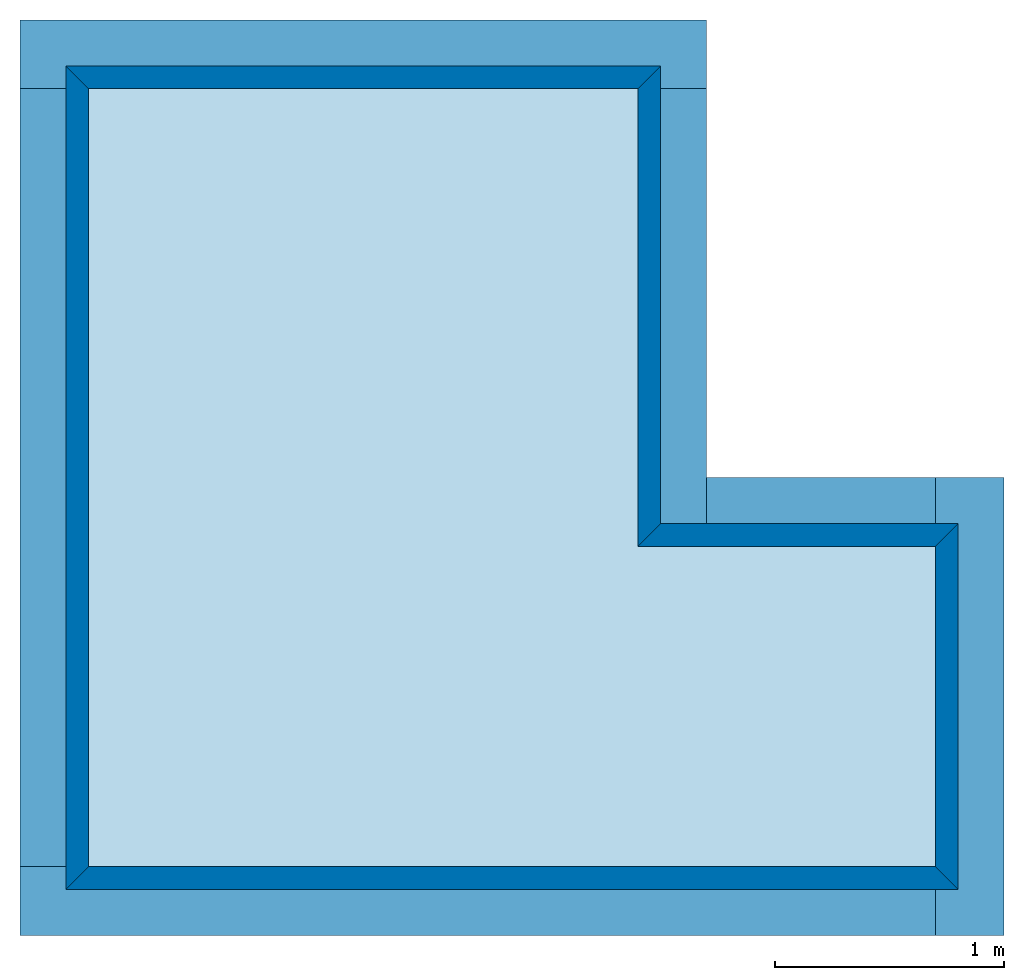
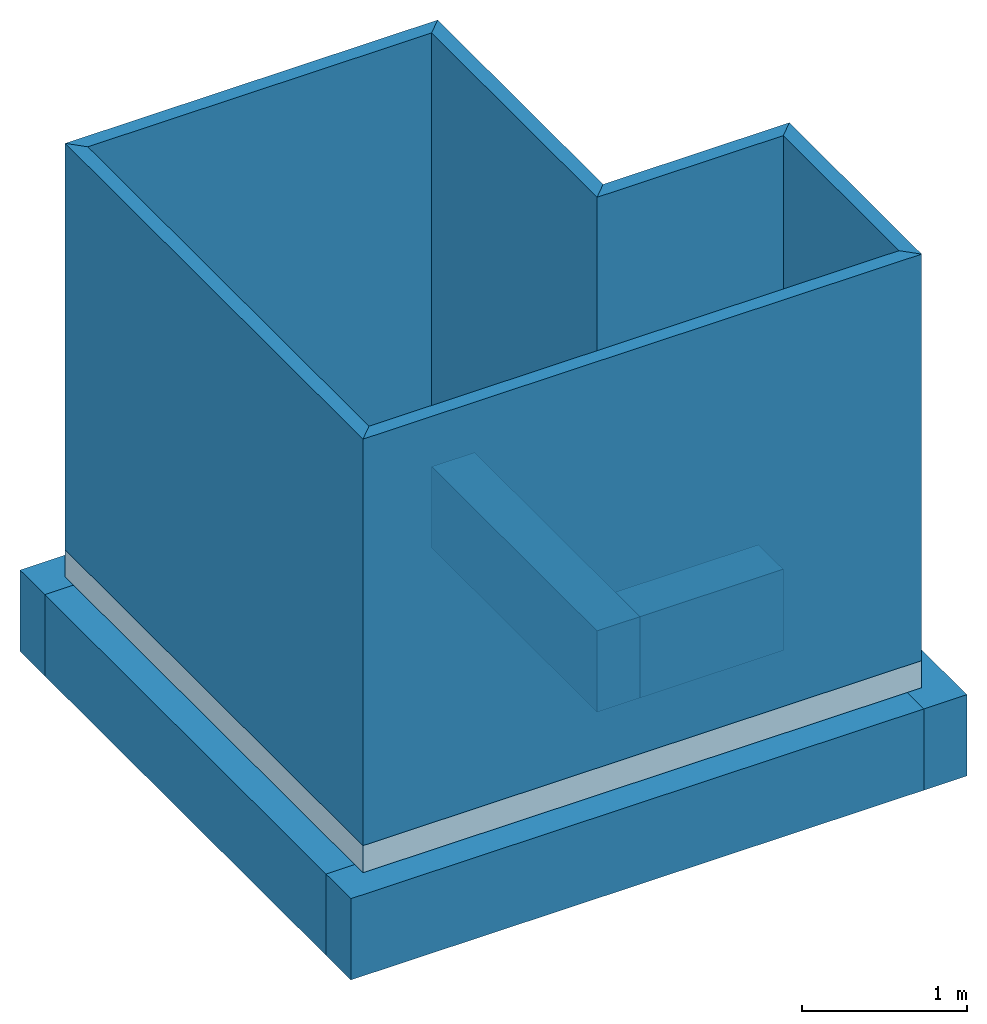
# One storey: 6 beams, 6 walls, 1 slab.
"""IFC4 building model written with IfcOpenShell, lengths in metres."""

from ifc_helpers import new_model, entity, si_unit, converted_unit, frame, frame_2d, origin_with_axes, place, context, subcontext, project, spatial, polyline, rectangle, outline, extrude, polygons, shape, material, layer, layer_set, layer_usage, material_profile, profile_set, profile_usage, type_object, element, save


model = new_model("IFC4")

# Units and contexts
model_context = context("Model", 3, precision=1e-05, world=origin_with_axes())
plan_context = context("Plan", 2, precision=1e-05, world=frame_2d((0.0, 0.0, 0.0), x_axis=(1.0, 0.0, 0.0)))
body_context = subcontext(model_context, "Body", "Model", "MODEL_VIEW")
ifc_project = project(units=[si_unit("LENGTHUNIT", "METRE"), converted_unit("PLANEANGLEUNIT", "degree", entity("IfcReal", 0.0174532925199433), si_unit("PLANEANGLEUNIT", "RADIAN"), dimensions=[0, 0, 0, 0, 0, 0, 0]), si_unit("AREAUNIT", "SQUARE_METRE"), si_unit("VOLUMEUNIT", "CUBIC_METRE")], contexts=[model_context, plan_context])

# Site, building, storey
site_placement = place(None, origin_with_axes())
site = spatial("IfcSite", under=ifc_project, at=site_placement)
building_placement = place(site_placement, origin_with_axes())
building = spatial("IfcBuilding", under=site, at=building_placement, Name="Building")
storey_placement = place(building_placement, origin_with_axes())
storey = spatial("IfcBuildingStorey", under=building, at=storey_placement, Name="Storey")

# Beams
ifc_material_1 = material(Name="beton")
ifc_material_profile = material_profile(ifc_material_1, rectangle(XDim=0.300000011920929, YDim=0.600000023841858))
ifc_profile_set = profile_set([ifc_material_profile])
ifc_profile_usage_1 = profile_usage(ifc_profile_set)
beam_type = type_object("IfcBeamType", Name="beam_type", PredefinedType="BEAM", material=ifc_profile_set)
beam_1_placement = place(storey_placement, frame((1.0, 1.20000004768372, 0.150000020861626), z_axis=(1.0, 4.37113882867379e-08, -4.37113882867379e-08), x_axis=(-4.37113882867379e-08, 1.0, 0.0)))
element("IfcBeam", 1, at=beam_1_placement, inside=storey, type_object=beam_type, material=ifc_profile_usage_1, Name="Beam", context=body_context, shape_type="SweptSolid", body=[
    extrude(rectangle(XDim=0.300000011920929, YDim=0.600000023841858), None, (0.0, 0.0, 1.0), 4.0),
])
ifc_profile_usage_2 = profile_usage(ifc_profile_set)
beam_2_placement = place(storey_placement, frame((5.15000009536743, 3.05000019073486, 0.150000020861626), z_axis=(0.0, -1.0, -1.62920684942947e-07), x_axis=(1.0, 0.0, 0.0)))
element("IfcBeam", 2, at=beam_2_placement, inside=storey, type_object=beam_type, material=ifc_profile_usage_2, Name="Beam", context=body_context, shape_type="SweptSolid", body=[
    extrude(rectangle(XDim=0.300000011920929, YDim=0.600000023841858), None, (0.0, 0.0, 1.0), 2.0),
])
ifc_profile_usage_3 = profile_usage(ifc_profile_set)
beam_3_placement = place(storey_placement, frame((4.0, 2.90000009536743, 0.149999976158142), z_axis=(1.0, 4.37113882867379e-08, -4.37113882867379e-08), x_axis=(-4.37113882867379e-08, 1.0, 0.0)))
element("IfcBeam", 3, at=beam_3_placement, inside=storey, type_object=beam_type, material=ifc_profile_usage_3, Name="Beam", context=body_context, shape_type="SweptSolid", body=[
    extrude(rectangle(XDim=0.300000011920929, YDim=0.600000023841858), None, (0.0, 0.0, 1.0), 1.0),
])
ifc_profile_usage_4 = profile_usage(ifc_profile_set)
beam_4_placement = place(storey_placement, frame((1.14999997615814, 1.35000014305115, 0.150000020861626), z_axis=(-3.25841369885893e-07, 1.0, -4.37113882867379e-08), x_axis=(-1.0, -3.25841369885893e-07, 0.0)))
element("IfcBeam", 4, at=beam_4_placement, inside=storey, type_object=beam_type, material=ifc_profile_usage_4, Name="Beam", context=body_context, shape_type="SweptSolid", body=[
    extrude(rectangle(XDim=0.300000011920929, YDim=0.600000023841858), None, (0.0, 0.0, 1.0), 3.39999961853027),
])
ifc_profile_usage_5 = profile_usage(ifc_profile_set)
beam_5_placement = place(storey_placement, frame((3.85000014305115, 2.75, 0.150000035762787), z_axis=(-3.25841369885893e-07, 1.0, -4.37113882867379e-08), x_axis=(-1.0, -3.25841369885893e-07, 0.0)))
element("IfcBeam", 5, at=beam_5_placement, inside=storey, type_object=beam_type, material=ifc_profile_usage_5, Name="Beam", context=body_context, shape_type="SweptSolid", body=[
    extrude(rectangle(XDim=0.300000011920929, YDim=0.600000023841858), None, (0.0, 0.0, 1.0), 2.0),
])
ifc_profile_usage_6 = profile_usage(ifc_profile_set)
beam_6_placement = place(storey_placement, frame((0.999999284744263, 4.90000009536743, 0.150000050663948), z_axis=(1.0, 4.37113882867379e-08, -4.37113882867379e-08), x_axis=(-4.37113882867379e-08, 1.0, 0.0)))
element("IfcBeam", 6, at=beam_6_placement, inside=storey, type_object=beam_type, material=ifc_profile_usage_6, Name="Beam", context=body_context, shape_type="SweptSolid", body=[
    extrude(rectangle(XDim=0.300000011920929, YDim=0.600000023841858), None, (0.0, 0.0, 1.0), 3.00000023841858),
])

# Slab
slab_placement = place(storey_placement, frame((1.19999992847443, 1.25, 0.450000047683716), z_axis=(0.0, 0.0, 1.0), x_axis=(1.0, 0.0, 0.0)))
element("IfcSlab", 7, at=slab_placement, inside=storey, Name="Vert", PredefinedType="BASESLAB", shapes=[
    shape(model_context, None, "Tessellation", [polygons([(1.49011611938477e-08, 5.96046447753906e-08, 1.05124797755707e-09), (3.90000057220459, 1.78813934326172e-07, -3.27794936083592e-07), (3.90000057220459, 1.60000002384186, 1.38499158808258e-08), (2.60000038146973, 1.60000002384186, -4.57547315591e-08), (2.59999990463257, 3.59999990463257, -1.05359376334491e-07), (-6.10947608947754e-07, 3.59999990463257, -3.06190628407421e-11), (1.49011611938477e-08, 5.96046447753906e-08, 0.200000002980232), (3.90000057220459, 1.78813934326172e-07, 0.199999675154686), (3.90000057220459, 1.60000002384186, 0.200000017881393), (2.60000038146973, 1.60000002384186, 0.199999958276749), (2.59999990463257, 3.59999990463257, 0.199999898672104), (-6.10947608947754e-07, 3.59999990463257, 0.200000002980232)], [[[1, 6, 5, 4, 3, 2]], [[7, 8, 9, 10, 11, 12]], [[5, 6, 12, 11]], [[3, 4, 10, 9]], [[1, 2, 8, 7]], [[6, 1, 7, 12]], [[4, 5, 11, 10]], [[2, 3, 9, 8]]])]),
])

# Walls
ifc_material_2 = material(Name="brick")
ifc_layer = layer(ifc_material_2, 0.100000001490116)
ifc_layer_set = layer_set([ifc_layer], Name="brick")
ifc_layer_usage_1 = layer_usage(ifc_layer_set, "AXIS2", "POSITIVE", 0.0)
wall_type = type_object("IfcWallType", Name="wall", PredefinedType="ELEMENTEDWALL", material=ifc_layer_set)
wall_1_placement = place(storey_placement, frame((1.19999992847443, 1.25, 0.650000035762787), z_axis=(0.0, 0.0, 1.0), x_axis=(1.0, 0.0, 0.0)))
element("IfcWall", 8, at=wall_1_placement, inside=storey, type_object=wall_type, material=ifc_layer_usage_1, Name="Wall", context=body_context, shape_type="SweptSolid", body=[
    extrude(outline(polyline([(1.27279198169708, -1.34350407123566), (1.41421341896057, -1.34350407123566), (-1.34350275993347, 1.41421496868134), (-1.34350287914276, 1.27279365062714), (1.27279198169708, -1.34350407123566)])), frame((1.94999980926514, 0.050000011920929, 0.0), z_axis=(0.0, 0.0, -1.0), x_axis=(0.707106411457062, -0.707107245922089, 0.0)), (-1.36593980570865e-08, 1.24176346982807e-09, -1.0), 3.0),
])
ifc_layer_usage_2 = layer_usage(ifc_layer_set, "AXIS2", "POSITIVE", 0.0)
wall_2_placement = place(storey_placement, frame((5.10000085830688, 1.25, 0.650000035762787), z_axis=(0.0, 0.0, 1.0), x_axis=(-1.62920684942947e-07, 1.0, 0.0)))
element("IfcWall", 9, at=wall_2_placement, inside=storey, type_object=wall_type, material=ifc_layer_usage_2, Name="Wall", context=body_context, shape_type="SweptSolid", body=[
    extrude(outline(polyline([(-0.601041197776794, -0.530329644680023), (-0.45961982011795, -0.530329644680023), (0.530330717563629, 0.459618866443634), (0.530330419540405, 0.601040482521057), (-0.601041197776794, -0.530329644680023)])), frame((0.799999952316284, 0.0500002279877663, 0.0), z_axis=(0.0, 0.0, -1.0), x_axis=(0.707107365131378, 0.707106232643127, 0.0)), (1.73846892437268e-08, -1.61429252187872e-08, -1.0), 3.0),
])
ifc_layer_usage_3 = layer_usage(ifc_layer_set, "AXIS2", "POSITIVE", 0.0)
wall_3_placement = place(storey_placement, frame((5.10000038146973, 2.84999990463257, 0.650000035762787), z_axis=(0.0, 0.0, 1.0), x_axis=(-1.0, -3.89414367418794e-07, 0.0)))
element("IfcWall", 10, at=wall_3_placement, inside=storey, type_object=wall_type, material=ifc_layer_usage_3, Name="Wall", context=body_context, shape_type="SweptSolid", body=[
    extrude(outline(polyline([(-0.530330181121826, -0.459619373083115), (-0.388909012079239, -0.459619373083115), (0.530330181121826, 0.459619432687759), (0.388908982276917, 0.459619402885437), (-0.530330181121826, -0.459619373083115)])), frame((0.699999928474426, 0.049999974668026, 0.0), z_axis=(0.0, 0.0, -1.0), x_axis=(-0.707106947898865, -0.707106649875641, 0.0)), (-4.96705387931229e-09, 0.0, -1.0), 3.0),
])
ifc_layer_usage_4 = layer_usage(ifc_layer_set, "AXIS2", "POSITIVE", 0.0)
wall_4_placement = place(storey_placement, frame((3.80000019073486, 2.74999952316284, 0.649999976158142), z_axis=(0.0, 0.0, 1.0), x_axis=(-1.62920684942947e-07, 1.0, 0.0)))
element("IfcWall", 11, at=wall_4_placement, inside=storey, type_object=wall_type, material=ifc_layer_usage_4, Name="Wall", context=body_context, shape_type="SweptSolid", body=[
    extrude(outline(polyline([(0.636396050453186, -0.707107067108154), (0.77781730890274, -0.707107067108154), (-0.636396169662476, 0.707107305526733), (-0.777817487716675, 0.707107067108154), (0.636396050453186, -0.707107067108154)])), frame((1.05000019073486, 0.0500002130866051, 2.98023206113385e-08), z_axis=(-2.98023064004838e-08, -2.98023223876953e-08, -1.0), x_axis=(-0.70710676908493, 0.70710676908493, 0.0)), (-1.11758708953857e-08, -5.33227080268261e-08, -1.0), 3.0),
])
ifc_layer_usage_5 = layer_usage(ifc_layer_set, "AXIS2", "POSITIVE", 0.0)
wall_5_placement = place(storey_placement, frame((3.79999923706055, 4.85000038146973, 0.649999976158142), z_axis=(0.0, 0.0, 1.0), x_axis=(-1.0, -3.89414367418794e-07, 0.0)))
element("IfcWall", 12, at=wall_5_placement, inside=storey, type_object=wall_type, material=ifc_layer_usage_5, Name="Wall", context=body_context, shape_type="SweptSolid", body=[
    extrude(outline(polyline([(-0.954594492912292, -0.883883059024811), (-0.813173294067383, -0.883883059024811), (0.883883953094482, 0.813172459602356), (0.883883953094482, 0.95459371805191), (-0.954594492912292, -0.883883059024811)])), frame((1.29999995231628, 0.0500002130866051, 0.0), z_axis=(0.0, 0.0, -1.0), x_axis=(0.707107245922089, 0.707106351852417, 0.0)), (4.96705387931229e-09, 0.0, -1.0), 3.0),
])
ifc_layer_usage_6 = layer_usage(ifc_layer_set, "AXIS2", "POSITIVE", 0.0)
wall_6_placement = place(storey_placement, frame((1.19999933242798, 4.84999895095825, 0.649999976158142), z_axis=(0.0, 0.0, 1.0), x_axis=(-1.62920684942947e-07, -1.0, 0.0)))
element("IfcWall", 13, at=wall_6_placement, inside=storey, type_object=wall_type, material=ifc_layer_usage_6, Name="Wall", context=body_context, shape_type="SweptSolid", body=[
    extrude(outline(polyline([(1.1667252779007, -1.23743712902069), (1.30814647674561, -1.23743712902069), (-1.2374359369278, 1.30814790725708), (-1.23743605613708, 1.16672670841217), (1.1667252779007, -1.23743712902069)])), frame((1.79999935626984, 0.0500000044703484, 0.0), z_axis=(0.0, 0.0, -1.0), x_axis=(0.707106411457062, -0.707107126712799, 0.0)), (-1.11758708953857e-08, 1.24176346982807e-09, -1.0), 3.0),
])

save(model, "model.ifc")
